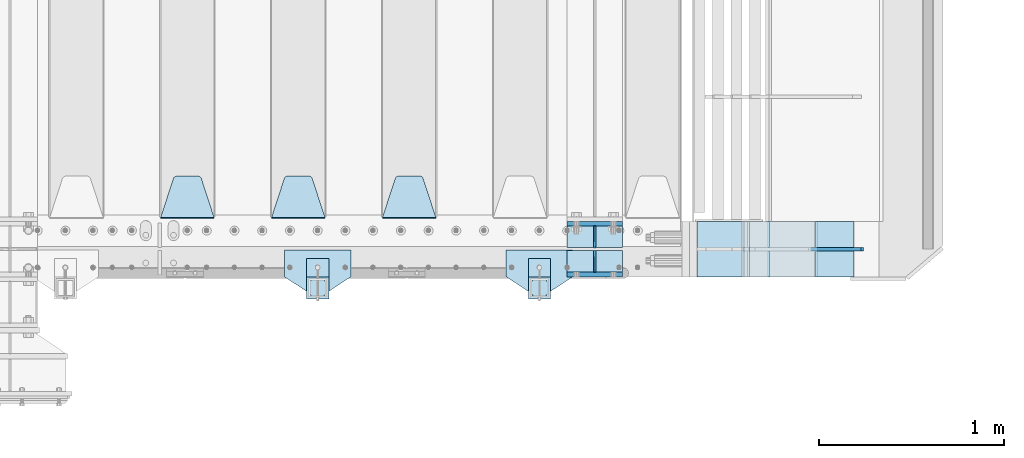
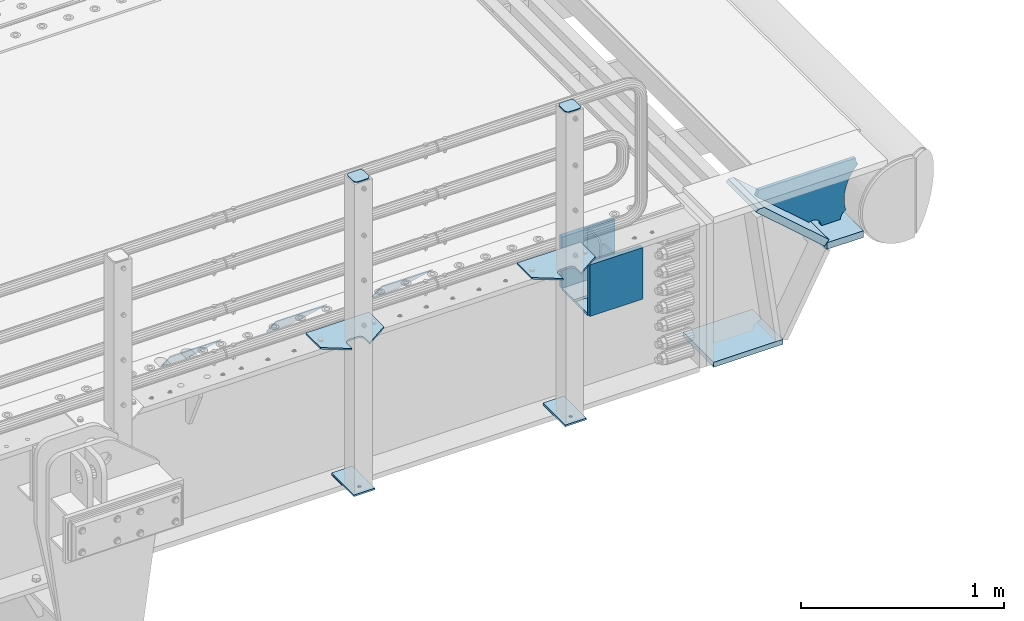
# One storey, part 168 of 193: 21 plates.
"""IFC2X3 building model written with IfcOpenShell, lengths in millimetres."""

from ifc_helpers import new_model, si_unit, frame, origin_with_axes, place, context, subcontext, project, spatial, faceted_brep, material, type_object, element, save


model = new_model("IFC2X3")

# Units and contexts
model_context = context("Model", 3, precision=1e-05, world=origin_with_axes())
body_context = subcontext(model_context, "Body", "Model", "MODEL_VIEW")
ifc_project = project(units=[si_unit("LENGTHUNIT", "METRE", prefix="MILLI"), si_unit("AREAUNIT", "SQUARE_METRE"), si_unit("VOLUMEUNIT", "CUBIC_METRE"), si_unit("MASSUNIT", "GRAM", prefix="KILO"), si_unit("TIMEUNIT", "SECOND"), si_unit("PLANEANGLEUNIT", "RADIAN"), si_unit("SOLIDANGLEUNIT", "STERADIAN"), si_unit("THERMODYNAMICTEMPERATUREUNIT", "DEGREE_CELSIUS"), si_unit("LUMINOUSINTENSITYUNIT", "LUMEN")], contexts=[model_context])

# Site, building, storey
site_placement = place(None, origin_with_axes())
site = spatial("IfcSite", under=ifc_project, at=site_placement, CompositionType="ELEMENT")
building_placement = place(site_placement, origin_with_axes())
building = spatial("IfcBuilding", under=site, at=building_placement, Name="Standard", CompositionType="ELEMENT")
storey_placement = place(building_placement, origin_with_axes())
storey = spatial("IfcBuildingStorey", under=building, at=storey_placement, Name="Undefined", CompositionType="ELEMENT", Elevation=0.0)

# Plates
ifc_material_1 = material(Name="STEEL/S355N")
plate_type_1 = type_object("IfcPlateType", PredefinedType="NOTDEFINED")
for number, where, z_axis, x_axis in (
    (1, (-29045.0, 23862.5, -339.999999999995), (0.0, 0.0, 1.0), (1.0, 0.0, 0.0)),
    (2, (-29045.0, 24137.5, -339.999999999995), (0.0, 0.0, 1.0), (1.0, 0.0, 0.0)),
):
    element("IfcPlate", number, at=place(storey_placement, frame(where, z_axis=z_axis, x_axis=x_axis)), inside=storey, type_object=plate_type_1, material=ifc_material_1, context=body_context, shape_type="Brep", body=[
        faceted_brep([(0.0, -12.5, 0.0), (0.0, -12.5, 310.0), (0.0, 12.5, 310.0), (0.0, 12.5, 0.0), (300.0, -12.5, 310.0), (300.0, 12.5, 310.0), (300.0, -12.5, 0.0), (300.0, 12.5, 0.0)], [[[0, 1, 2, 3]], [[1, 4, 5, 2]], [[4, 6, 7, 5]], [[6, 0, 3, 7]], [[5, 7, 3, 2]], [[6, 4, 1, 0]]]),
    ])
plate_type_2 = type_object("IfcPlateType", PredefinedType="NOTDEFINED")
for number, where, z_axis, x_axis in (
    (3, (-29045.0, 24008.0, -342.999999999995), (0.0, 1.0, 0.0), (1.0, 0.0, 0.0)),
    (4, (-29045.0, 23992.0, -342.999999999995), (0.0, -1.0, 0.0), (1.0, 0.0, 0.0)),
):
    element("IfcPlate", number, at=place(storey_placement, frame(where, z_axis=z_axis, x_axis=x_axis)), inside=storey, type_object=plate_type_2, material=ifc_material_1, context=body_context, shape_type="Brep", body=[
        faceted_brep([(0.0, -7.0, 0.0), (0.0, -7.0, 117.0), (0.0, 7.0, 117.0), (0.0, 7.0, 0.0), (300.0, -7.0, 117.0), (300.0, 7.0, 117.0), (300.0, -7.0, 0.0), (300.0, 7.0, 0.0)], [[[0, 1, 2, 3]], [[1, 4, 5, 2]], [[4, 6, 7, 5]], [[6, 0, 3, 7]], [[5, 7, 3, 2]], [[6, 4, 1, 0]]]),
    ])
plate_type_3 = type_object("IfcPlateType", PredefinedType="NOTDEFINED")
for number, where, z_axis, x_axis in (
    (5, (-28895.0, 23992.0, -29.9999999999945), (0.0, 0.0, -1.0), (0.0, -1.0, 0.0)),
    (6, (-28895.0, 24008.0, -29.9999999999945), (0.0, 0.0, -1.0), (0.0, 1.0, 0.0)),
):
    element("IfcPlate", number, at=place(storey_placement, frame(where, z_axis=z_axis, x_axis=x_axis)), inside=storey, type_object=plate_type_3, material=ifc_material_1, context=body_context, shape_type="Brep", body=[
        faceted_brep([(0.0, -5.0, 30.0), (0.0, -5.0, 306.0), (0.0, 5.0, 306.0), (0.0, 5.0, 30.0), (117.0, -5.0, 306.0), (117.0, 5.0, 306.0), (117.0, -5.0, 0.0), (117.0, 5.0, 0.0), (30.0, -5.0, 0.0), (30.0, 5.0, 0.0), (24.7905546699913, -5.0, 0.455767409633758), (24.7905546699913, 5.0, 0.455767409633758), (19.7393957002314, -5.0, 1.80922137642275), (19.7393957002314, 5.0, 1.80922137642275), (15.0, -5.0, 4.01923788646684), (15.0, 5.0, 4.01923788646684), (10.7163717094045, -5.0, 7.01866670643066), (10.7163717094045, 5.0, 7.01866670643066), (7.01866670642994, -5.0, 10.7163717094038), (7.01866670642994, 5.0, 10.7163717094038), (4.01923788646673, -5.0, 15.0), (4.01923788646673, 5.0, 15.0), (1.80922137642119, -5.0, 19.7393957002299), (1.80922137642119, 5.0, 19.7393957002299), (0.455767409632244, -5.0, 24.7905546699921), (0.455767409632244, 5.0, 24.7905546699921)], [[[0, 1, 2, 3]], [[1, 4, 5, 2]], [[4, 6, 7, 5]], [[6, 8, 9, 7]], [[8, 10, 11, 9]], [[10, 12, 13, 11]], [[12, 14, 15, 13]], [[14, 16, 17, 15]], [[16, 18, 19, 17]], [[18, 20, 21, 19]], [[20, 22, 23, 21]], [[22, 24, 25, 23]], [[24, 0, 3, 25]], [[5, 7, 9, 11, 13, 15, 17, 19, 21, 23, 25, 3, 2]], [[24, 22, 20, 18, 16, 14, 12, 10, 8, 6, 4, 1, 0]]]),
    ])
plate_type_4 = type_object("IfcPlateType", PredefinedType="NOTDEFINED")
plate_1_placement = place(storey_placement, frame((-29755.0, 24168.232233047, -1.76776695296758), z_axis=(0.0, 0.707106781186547, -0.707106781186548), x_axis=(-1.0, 0.0, 0.0)))
element("IfcPlate", 7, at=plate_1_placement, inside=storey, type_object=plate_type_4, material=ifc_material_1, context=body_context, shape_type="Brep", body=[
    faceted_brep([(0.0, -2.5, 0.0), (69.345504679477, -2.50000000000364, 300.171731424831), (69.345504679477, 2.49999999999636, 300.171731424831), (0.0, 2.5, 0.0), (70.9274061199576, -2.50000000000364, 304.897442415397), (70.9274061199576, 2.49999999999636, 304.897442415397), (73.3818627772307, -2.50000000000364, 309.234538108529), (73.3818627772307, 2.49999999999636, 309.234538108529), (76.6187032999551, -2.50000000000728, 313.023683126103), (76.6187032999551, 2.49999999999636, 313.023683126103), (80.5190132704993, -2.50000000000364, 316.125672595372), (80.5190132704993, 2.49999999999636, 316.125672595368), (84.9395038596849, -2.50000000000364, 318.426546230472), (84.9395038596849, 2.49999999999636, 318.426546230476), (89.7177759439219, -2.50000000000364, 319.841774983273), (89.7177759439219, 2.49999999999636, 319.841774983277), (94.678286292652, -2.50000000000364, 320.319366455074), (94.678286292652, 2.49999999999636, 320.319366455074), (195.321713707348, -2.50000000000364, 320.319366455074), (195.321713707348, 2.49999999999636, 320.319366455074), (200.282224056078, -2.50000000000364, 319.841774983273), (200.282224056078, 2.49999999999636, 319.841774983277), (205.060496140315, -2.50000000000364, 318.426546230472), (205.060496140315, 2.49999999999636, 318.426546230472), (209.480986729501, -2.50000000000364, 316.125672595372), (209.480986729501, 2.49999999999636, 316.125672595368), (213.381296700045, -2.50000000000728, 313.023683126103), (213.381296700045, 2.49999999999272, 313.023683126103), (216.618137222769, -2.50000000000364, 309.234538108525), (216.618137222769, 2.49999999999636, 309.234538108522), (219.072593880042, -2.50000000000364, 304.897442415397), (219.072593880042, 2.49999999999636, 304.897442415397), (220.654495320523, -2.50000000000364, 300.171731424831), (220.654495320523, 2.49999999999636, 300.171731424831), (290.0, -2.50000000000364, 0.0), (290.0, 2.49999999999636, 0.0)], [[[0, 1, 2, 3]], [[1, 4, 5, 2]], [[4, 6, 7, 5]], [[6, 8, 9, 7]], [[8, 10, 11, 9]], [[10, 12, 13, 11]], [[12, 14, 15, 13]], [[14, 16, 17, 15]], [[16, 18, 19, 17]], [[18, 20, 21, 19]], [[20, 22, 23, 21]], [[22, 24, 25, 23]], [[24, 26, 27, 25]], [[26, 28, 29, 27]], [[28, 30, 31, 29]], [[30, 32, 33, 31]], [[32, 34, 35, 33]], [[34, 0, 3, 35]], [[5, 7, 9, 11, 13, 15, 17, 19, 21, 23, 25, 27, 29, 31, 33, 35, 3, 2]], [[34, 32, 30, 28, 26, 24, 22, 20, 18, 16, 14, 12, 10, 8, 6, 4, 1, 0]]]),
])
plate_2_placement = place(storey_placement, frame((-30355.0, 24168.232233047, -1.76776695296758), z_axis=(0.0, 0.707106781186547, -0.707106781186548), x_axis=(-1.0, 0.0, 0.0)))
element("IfcPlate", 8, at=plate_2_placement, inside=storey, type_object=plate_type_4, material=ifc_material_1, context=body_context, shape_type="Brep", body=[
    faceted_brep([(0.0, -2.5, 0.0), (69.345504679477, -2.50000000000364, 300.171731424831), (69.345504679477, 2.49999999999636, 300.171731424831), (0.0, 2.5, 0.0), (70.9274061199576, -2.50000000000364, 304.897442415397), (70.9274061199576, 2.49999999999636, 304.897442415397), (73.3818627772307, -2.50000000000364, 309.234538108529), (73.3818627772307, 2.49999999999636, 309.234538108529), (76.6187032999551, -2.50000000000728, 313.023683126103), (76.6187032999551, 2.49999999999636, 313.023683126103), (80.5190132704993, -2.50000000000364, 316.125672595372), (80.5190132704993, 2.49999999999636, 316.125672595368), (84.9395038596849, -2.50000000000364, 318.426546230472), (84.9395038596849, 2.49999999999636, 318.426546230476), (89.7177759439219, -2.50000000000364, 319.841774983273), (89.7177759439219, 2.49999999999636, 319.841774983277), (94.678286292652, -2.50000000000364, 320.319366455074), (94.678286292652, 2.49999999999636, 320.319366455074), (195.321713707348, -2.50000000000364, 320.319366455074), (195.321713707348, 2.49999999999636, 320.319366455074), (200.282224056078, -2.50000000000364, 319.841774983273), (200.282224056078, 2.49999999999636, 319.841774983277), (205.060496140315, -2.50000000000364, 318.426546230472), (205.060496140315, 2.49999999999636, 318.426546230472), (209.480986729501, -2.50000000000364, 316.125672595372), (209.480986729501, 2.49999999999636, 316.125672595368), (213.381296700045, -2.50000000000728, 313.023683126103), (213.381296700045, 2.49999999999272, 313.023683126103), (216.618137222769, -2.50000000000364, 309.234538108525), (216.618137222769, 2.49999999999636, 309.234538108522), (219.072593880042, -2.50000000000364, 304.897442415397), (219.072593880042, 2.49999999999636, 304.897442415397), (220.654495320523, -2.50000000000364, 300.171731424831), (220.654495320523, 2.49999999999636, 300.171731424831), (290.0, -2.50000000000364, 0.0), (290.0, 2.49999999999636, 0.0)], [[[0, 1, 2, 3]], [[1, 4, 5, 2]], [[4, 6, 7, 5]], [[6, 8, 9, 7]], [[8, 10, 11, 9]], [[10, 12, 13, 11]], [[12, 14, 15, 13]], [[14, 16, 17, 15]], [[16, 18, 19, 17]], [[18, 20, 21, 19]], [[20, 22, 23, 21]], [[22, 24, 25, 23]], [[24, 26, 27, 25]], [[26, 28, 29, 27]], [[28, 30, 31, 29]], [[30, 32, 33, 31]], [[32, 34, 35, 33]], [[34, 0, 3, 35]], [[5, 7, 9, 11, 13, 15, 17, 19, 21, 23, 25, 27, 29, 31, 33, 35, 3, 2]], [[34, 32, 30, 28, 26, 24, 22, 20, 18, 16, 14, 12, 10, 8, 6, 4, 1, 0]]]),
])
plate_3_placement = place(storey_placement, frame((-30955.0, 24168.232233047, -1.76776695296758), z_axis=(0.0, 0.707106781186547, -0.707106781186548), x_axis=(-1.0, 0.0, 0.0)))
element("IfcPlate", 9, at=plate_3_placement, inside=storey, type_object=plate_type_4, material=ifc_material_1, context=body_context, shape_type="Brep", body=[
    faceted_brep([(0.0, -2.5, 0.0), (69.345504679477, -2.50000000000364, 300.171731424831), (69.345504679477, 2.49999999999636, 300.171731424831), (0.0, 2.5, 0.0), (70.9274061199576, -2.50000000000364, 304.897442415397), (70.9274061199576, 2.49999999999636, 304.897442415397), (73.3818627772307, -2.50000000000364, 309.234538108529), (73.3818627772307, 2.49999999999636, 309.234538108529), (76.6187032999551, -2.50000000000728, 313.023683126103), (76.6187032999551, 2.49999999999636, 313.023683126103), (80.5190132704993, -2.50000000000364, 316.125672595372), (80.5190132704993, 2.49999999999636, 316.125672595368), (84.9395038596849, -2.50000000000364, 318.426546230472), (84.9395038596849, 2.49999999999636, 318.426546230476), (89.7177759439219, -2.50000000000364, 319.841774983273), (89.7177759439219, 2.49999999999636, 319.841774983277), (94.678286292652, -2.50000000000364, 320.319366455074), (94.678286292652, 2.49999999999636, 320.319366455074), (195.321713707348, -2.50000000000364, 320.319366455074), (195.321713707348, 2.49999999999636, 320.319366455074), (200.282224056078, -2.50000000000364, 319.841774983273), (200.282224056078, 2.49999999999636, 319.841774983277), (205.060496140315, -2.50000000000364, 318.426546230472), (205.060496140315, 2.49999999999636, 318.426546230472), (209.480986729501, -2.50000000000364, 316.125672595372), (209.480986729501, 2.49999999999636, 316.125672595368), (213.381296700045, -2.50000000000728, 313.023683126103), (213.381296700045, 2.49999999999272, 313.023683126103), (216.618137222769, -2.50000000000364, 309.234538108525), (216.618137222769, 2.49999999999636, 309.234538108522), (219.072593880042, -2.50000000000364, 304.897442415397), (219.072593880042, 2.49999999999636, 304.897442415397), (220.654495320523, -2.50000000000364, 300.171731424831), (220.654495320523, 2.49999999999636, 300.171731424831), (290.0, -2.50000000000364, 0.0), (290.0, 2.49999999999636, 0.0)], [[[0, 1, 2, 3]], [[1, 4, 5, 2]], [[4, 6, 7, 5]], [[6, 8, 9, 7]], [[8, 10, 11, 9]], [[10, 12, 13, 11]], [[12, 14, 15, 13]], [[14, 16, 17, 15]], [[16, 18, 19, 17]], [[18, 20, 21, 19]], [[20, 22, 23, 21]], [[22, 24, 25, 23]], [[24, 26, 27, 25]], [[26, 28, 29, 27]], [[28, 30, 31, 29]], [[30, 32, 33, 31]], [[32, 34, 35, 33]], [[34, 0, 3, 35]], [[5, 7, 9, 11, 13, 15, 17, 19, 21, 23, 25, 27, 29, 31, 33, 35, 3, 2]], [[34, 32, 30, 28, 26, 24, 22, 20, 18, 16, 14, 12, 10, 8, 6, 4, 1, 0]]]),
])
ifc_material_2 = material(Name="STEEL/S355J2")
plate_type_5 = type_object("IfcPlateType", PredefinedType="NOTDEFINED")
plate_4_placement = place(storey_placement, frame((-29015.0, 23995.0, 5.00000000004911), z_axis=(0.0, -1.0, 0.0), x_axis=(-1.0, 0.0, 0.0)))
element("IfcPlate", 10, at=plate_4_placement, inside=storey, type_object=plate_type_5, material=ifc_material_2, context=body_context, shape_type="Brep", body=[
    faceted_brep([(0.0, -5.0, 0.0), (2.31396552408114e-06, -5.0, 145.0), (2.31396552408114e-06, 5.0, 145.0), (0.0, 5.0, 0.0), (130.0, -5.0, 230.0), (130.0, 5.0, 230.0), (130.0, -5.0, 180.0), (130.0, 5.0, 180.0), (130.48036798992, -5.0, 175.122741949595), (130.48036798992, 5.0, 175.122741949595), (131.903011687216, -5.0, 170.432914190871), (131.903011687216, 5.0, 170.432914190871), (134.213259692435, -5.0, 166.110744174512), (134.213259692435, 5.0, 166.110744174512), (137.322330470335, -5.0, 162.322330470335), (137.322330470335, 5.0, 162.322330470335), (141.110744174512, -5.0, 159.213259692435), (141.110744174512, 5.0, 159.213259692435), (145.432914190871, -5.0, 156.903011687216), (145.432914190871, 5.0, 156.903011687216), (150.122741949595, -5.0, 155.48036798992), (150.122741949595, 5.0, 155.48036798992), (155.0, -5.0, 155.0), (155.0, 5.0, 155.0), (205.0, -5.0, 155.0), (205.0, 5.0, 155.0), (209.877258050405, -5.0, 155.48036798992), (209.877258050405, 5.0, 155.48036798992), (214.567085809129, -5.0, 156.903011687216), (214.567085809129, 5.0, 156.903011687216), (218.889255825488, -5.0, 159.213259692435), (218.889255825488, 5.0, 159.213259692435), (222.677669529665, -5.0, 162.322330470335), (222.677669529665, 5.0, 162.322330470335), (225.786740307565, -5.0, 166.110744174512), (225.786740307565, 5.0, 166.110744174512), (228.096988312784, -5.0, 170.432914190871), (228.096988312784, 5.0, 170.432914190871), (229.51963201008, -5.0, 175.122741949595), (229.51963201008, 5.0, 175.122741949595), (230.0, -5.0, 180.0), (230.0, 5.0, 180.0), (230.0, -5.0, 230.0), (230.0, 5.0, 230.0), (360.0, -5.0, 145.0), (360.0, 5.0, 145.0), (360.0, -5.0, -7.27595761418343e-12), (360.0, 5.0, -7.27595761418343e-12)], [[[0, 1, 2, 3]], [[1, 4, 5, 2]], [[4, 6, 7, 5]], [[6, 8, 9, 7]], [[8, 10, 11, 9]], [[10, 12, 13, 11]], [[12, 14, 15, 13]], [[14, 16, 17, 15]], [[16, 18, 19, 17]], [[18, 20, 21, 19]], [[20, 22, 23, 21]], [[22, 24, 25, 23]], [[24, 26, 27, 25]], [[26, 28, 29, 27]], [[28, 30, 31, 29]], [[30, 32, 33, 31]], [[32, 34, 35, 33]], [[34, 36, 37, 35]], [[36, 38, 39, 37]], [[38, 40, 41, 39]], [[40, 42, 43, 41]], [[42, 44, 45, 43]], [[44, 46, 47, 45]], [[46, 0, 3, 47]], [[5, 7, 9, 11, 13, 15, 17, 19, 21, 23, 25, 27, 29, 31, 33, 35, 37, 39, 41, 43, 45, 47, 3, 2]], [[46, 44, 42, 40, 38, 36, 34, 32, 30, 28, 26, 24, 22, 20, 18, 16, 14, 12, 10, 8, 6, 4, 1, 0]]]),
])
plate_5_placement = place(storey_placement, frame((-30215.0, 23995.0, 5.00000000004911), z_axis=(0.0, -1.0, 0.0), x_axis=(-1.0, 0.0, 0.0)))
element("IfcPlate", 11, at=plate_5_placement, inside=storey, type_object=plate_type_5, material=ifc_material_2, context=body_context, shape_type="Brep", body=[
    faceted_brep([(0.0, -5.0, 0.0), (2.31396552408114e-06, -5.0, 145.0), (2.31396552408114e-06, 5.0, 145.0), (0.0, 5.0, 0.0), (130.0, -5.0, 230.0), (130.0, 5.0, 230.0), (130.0, -5.0, 180.0), (130.0, 5.0, 180.0), (130.48036798992, -5.0, 175.122741949595), (130.48036798992, 5.0, 175.122741949595), (131.903011687216, -5.0, 170.432914190871), (131.903011687216, 5.0, 170.432914190871), (134.213259692435, -5.0, 166.110744174512), (134.213259692435, 5.0, 166.110744174512), (137.322330470335, -5.0, 162.322330470335), (137.322330470335, 5.0, 162.322330470335), (141.110744174512, -5.0, 159.213259692435), (141.110744174512, 5.0, 159.213259692435), (145.432914190871, -5.0, 156.903011687216), (145.432914190871, 5.0, 156.903011687216), (150.122741949595, -5.0, 155.48036798992), (150.122741949595, 5.0, 155.48036798992), (155.0, -5.0, 155.0), (155.0, 5.0, 155.0), (205.0, -5.0, 155.0), (205.0, 5.0, 155.0), (209.877258050405, -5.0, 155.48036798992), (209.877258050405, 5.0, 155.48036798992), (214.567085809129, -5.0, 156.903011687216), (214.567085809129, 5.0, 156.903011687216), (218.889255825488, -5.0, 159.213259692435), (218.889255825488, 5.0, 159.213259692435), (222.677669529665, -5.0, 162.322330470335), (222.677669529665, 5.0, 162.322330470335), (225.786740307565, -5.0, 166.110744174512), (225.786740307565, 5.0, 166.110744174512), (228.096988312784, -5.0, 170.432914190871), (228.096988312784, 5.0, 170.432914190871), (229.51963201008, -5.0, 175.122741949595), (229.51963201008, 5.0, 175.122741949595), (230.0, -5.0, 180.0), (230.0, 5.0, 180.0), (230.0, -5.0, 230.0), (230.0, 5.0, 230.0), (360.0, -5.0, 145.0), (360.0, 5.0, 145.0), (360.0, -5.0, -7.27595761418343e-12), (360.0, 5.0, -7.27595761418343e-12)], [[[0, 1, 2, 3]], [[1, 4, 5, 2]], [[4, 6, 7, 5]], [[6, 8, 9, 7]], [[8, 10, 11, 9]], [[10, 12, 13, 11]], [[12, 14, 15, 13]], [[14, 16, 17, 15]], [[16, 18, 19, 17]], [[18, 20, 21, 19]], [[20, 22, 23, 21]], [[22, 24, 25, 23]], [[24, 26, 27, 25]], [[26, 28, 29, 27]], [[28, 30, 31, 29]], [[30, 32, 33, 31]], [[32, 34, 35, 33]], [[34, 36, 37, 35]], [[36, 38, 39, 37]], [[38, 40, 41, 39]], [[40, 42, 43, 41]], [[42, 44, 45, 43]], [[44, 46, 47, 45]], [[46, 0, 3, 47]], [[5, 7, 9, 11, 13, 15, 17, 19, 21, 23, 25, 27, 29, 31, 33, 35, 37, 39, 41, 43, 45, 47, 3, 2]], [[46, 44, 42, 40, 38, 36, 34, 32, 30, 28, 26, 24, 22, 20, 18, 16, 14, 12, 10, 8, 6, 4, 1, 0]]]),
])
plate_type_6 = type_object("IfcPlateType", PredefinedType="NOTDEFINED")
for number, where, z_axis, x_axis in (
    (12, (-29135.0000000001, 23949.9999999998, -850.000000000002), (0.0, -1.0, 0.0), (-1.0, 0.0, 0.0)),
    (13, (-30335.0000000001, 23949.9999999998, -850.000000000002), (0.0, -1.0, 0.0), (-1.0, 0.0, 0.0)),
):
    element("IfcPlate", number, at=place(storey_placement, frame(where, z_axis=z_axis, x_axis=x_axis)), inside=storey, type_object=plate_type_6, material=ifc_material_2, context=body_context, shape_type="Brep", body=[
        faceted_brep([(53.6360389691836, -5.0, 176.363961030467), (53.6360389691836, 5.0, 176.363961030467), (59.9999999998618, 5.0, 178.999999999789), (59.9999999998618, -5.0, 178.999999999789), (66.3639610305399, 5.0, 176.363961030467), (66.3639610305399, -5.0, 176.363961030467), (68.9999999998618, 5.0, 169.999999999789), (68.9999999998618, -5.0, 169.999999999789), (66.3639610305399, 5.0, 163.636038969111), (66.3639610305399, -5.0, 163.636038969111), (59.9999999998618, 5.0, 160.999999999789), (59.9999999998618, -5.0, 160.999999999789), (53.6360389691836, 5.0, 163.636038969111), (53.6360389691836, -5.0, 163.636038969111), (50.9999999998618, 5.0, 169.999999999789), (50.9999999998618, -5.0, 169.999999999789), (120.0, -5.0, 0.0), (120.0, -5.0, 220.0), (0.0, -5.0, 220.0), (0.0, -5.0, 0.0), (0.0, 5.0, 0.0), (120.0, 5.0, 0.0), (120.0, 5.0, 220.0), (0.0, 5.0, 220.0)], [[[0, 1, 2, 3]], [[3, 2, 4, 5]], [[5, 4, 6, 7]], [[7, 6, 8, 9]], [[9, 8, 10, 11]], [[11, 10, 12, 13]], [[13, 12, 14, 15]], [[15, 14, 1, 0]], [[16, 17, 18, 19], [11, 13, 15, 0, 3, 5, 7, 9]], [[16, 19, 20, 21]], [[17, 16, 21, 22]], [[18, 17, 22, 23]], [[19, 18, 23, 20]], [[22, 21, 20, 23], [2, 1, 14, 12, 10, 8, 6, 4]]]),
    ])
plate_type_7 = type_object("IfcPlateType", PredefinedType="NOTDEFINED")
plate_6_placement = place(storey_placement, frame((-29239.0000000001, 23833.9999999998, 1012.50000000001), z_axis=(0.0, -1.0, 0.0), x_axis=(1.0, 0.0, 0.0)))
element("IfcPlate", 14, at=plate_6_placement, inside=storey, type_object=plate_type_7, material=ifc_material_2, context=body_context, shape_type="Brep", body=[
    faceted_brep([(0.0, -2.5, 19.0), (0.0, -2.5, 69.0), (0.0, 2.5, 69.0), (0.0, 2.5, 19.0), (0.476369668544066, -2.5, 73.2278977451715), (0.476369668544066, 2.5, 73.2278977451715), (1.88159150985302, -2.5, 77.2437910432345), (1.88159150985302, 2.5, 77.2437910432345), (4.14520183310742, -2.5, 80.8463062353148), (4.14520183310742, 2.5, 80.8463062353148), (7.15369376468516, -2.5, 83.8547981668926), (7.15369376468516, 2.5, 83.8547981668926), (10.7562089567655, -2.5, 86.118408490147), (10.7562089567655, 2.5, 86.118408490147), (14.7721022548285, -2.5, 87.5236303314559), (14.7721022548285, 2.5, 87.5236303314559), (19.0, -2.5, 88.0), (19.0, 2.5, 88.0), (69.0, -2.5, 88.0), (69.0, 2.5, 88.0), (73.2278977451715, -2.5, 87.5236303314559), (73.2278977451715, 2.5, 87.5236303314559), (77.2437910432345, -2.5, 86.118408490147), (77.2437910432345, 2.5, 86.118408490147), (80.8463062353148, -2.5, 83.8547981668926), (80.8463062353148, 2.5, 83.8547981668926), (83.8547981668926, -2.5, 80.8463062353148), (83.8547981668926, 2.5, 80.8463062353148), (86.118408490147, -2.5, 77.2437910432345), (86.118408490147, 2.5, 77.2437910432345), (87.5236303314559, -2.5, 73.2278977451715), (87.5236303314559, 2.5, 73.2278977451715), (88.0, -2.5, 69.0), (88.0, 2.5, 69.0), (88.0, -2.5, 19.0), (88.0, 2.5, 19.0), (87.5236303314559, -2.5, 14.7721022548285), (87.5236303314559, 2.5, 14.7721022548285), (86.118408490147, -2.5, 10.7562089567655), (86.118408490147, 2.5, 10.7562089567655), (83.8547981668926, -2.5, 7.15369376468516), (83.8547981668926, 2.5, 7.15369376468516), (80.8463062353148, -2.5, 4.14520183310742), (80.8463062353148, 2.5, 4.14520183310742), (77.2437910432345, -2.5, 1.88159150985302), (77.2437910432345, 2.5, 1.88159150985302), (73.2278977451715, -2.5, 0.476369668544066), (73.2278977451715, 2.5, 0.476369668544066), (69.0, -2.5, 0.0), (69.0, 2.5, 0.0), (19.0, -2.5, 0.0), (19.0, 2.5, 0.0), (14.7721022548285, -2.5, 0.476369668544066), (14.7721022548285, 2.5, 0.476369668544066), (10.7562089567655, -2.5, 1.88159150985302), (10.7562089567655, 2.5, 1.88159150985302), (7.15369376468516, -2.5, 4.14520183310742), (7.15369376468516, 2.5, 4.14520183310742), (4.14520183310742, -2.5, 7.15369376468516), (4.14520183310742, 2.5, 7.15369376468516), (1.88159150985302, -2.5, 10.7562089567655), (1.88159150985302, 2.5, 10.7562089567655), (0.476369668544066, -2.5, 14.7721022548285), (0.476369668544066, 2.5, 14.7721022548285)], [[[0, 1, 2, 3]], [[1, 4, 5, 2]], [[4, 6, 7, 5]], [[6, 8, 9, 7]], [[8, 10, 11, 9]], [[10, 12, 13, 11]], [[12, 14, 15, 13]], [[14, 16, 17, 15]], [[16, 18, 19, 17]], [[18, 20, 21, 19]], [[20, 22, 23, 21]], [[22, 24, 25, 23]], [[24, 26, 27, 25]], [[26, 28, 29, 27]], [[28, 30, 31, 29]], [[30, 32, 33, 31]], [[32, 34, 35, 33]], [[34, 36, 37, 35]], [[36, 38, 39, 37]], [[38, 40, 41, 39]], [[40, 42, 43, 41]], [[42, 44, 45, 43]], [[44, 46, 47, 45]], [[46, 48, 49, 47]], [[48, 50, 51, 49]], [[50, 52, 53, 51]], [[52, 54, 55, 53]], [[54, 56, 57, 55]], [[56, 58, 59, 57]], [[58, 60, 61, 59]], [[60, 62, 63, 61]], [[62, 0, 3, 63]], [[5, 7, 9, 11, 13, 15, 17, 19, 21, 23, 25, 27, 29, 31, 33, 35, 37, 39, 41, 43, 45, 47, 49, 51, 53, 55, 57, 59, 61, 63, 3, 2]], [[62, 60, 58, 56, 54, 52, 50, 48, 46, 44, 42, 40, 38, 36, 34, 32, 30, 28, 26, 24, 22, 20, 18, 16, 14, 12, 10, 8, 6, 4, 1, 0]]]),
])
plate_7_placement = place(storey_placement, frame((-30439.0000000001, 23833.9999999998, 1012.50000000001), z_axis=(0.0, -1.0, 0.0), x_axis=(1.0, 0.0, 0.0)))
element("IfcPlate", 15, at=plate_7_placement, inside=storey, type_object=plate_type_7, material=ifc_material_2, context=body_context, shape_type="Brep", body=[
    faceted_brep([(0.0, -2.5, 19.0), (0.0, -2.5, 69.0), (0.0, 2.5, 69.0), (0.0, 2.5, 19.0), (0.476369668544066, -2.5, 73.2278977451715), (0.476369668544066, 2.5, 73.2278977451715), (1.88159150985302, -2.5, 77.2437910432345), (1.88159150985302, 2.5, 77.2437910432345), (4.14520183310742, -2.5, 80.8463062353148), (4.14520183310742, 2.5, 80.8463062353148), (7.15369376468516, -2.5, 83.8547981668926), (7.15369376468516, 2.5, 83.8547981668926), (10.7562089567655, -2.5, 86.118408490147), (10.7562089567655, 2.5, 86.118408490147), (14.7721022548285, -2.5, 87.5236303314559), (14.7721022548285, 2.5, 87.5236303314559), (19.0, -2.5, 88.0), (19.0, 2.5, 88.0), (69.0, -2.5, 88.0), (69.0, 2.5, 88.0), (73.2278977451715, -2.5, 87.5236303314559), (73.2278977451715, 2.5, 87.5236303314559), (77.2437910432345, -2.5, 86.118408490147), (77.2437910432345, 2.5, 86.118408490147), (80.8463062353148, -2.5, 83.8547981668926), (80.8463062353148, 2.5, 83.8547981668926), (83.8547981668926, -2.5, 80.8463062353148), (83.8547981668926, 2.5, 80.8463062353148), (86.118408490147, -2.5, 77.2437910432345), (86.118408490147, 2.5, 77.2437910432345), (87.5236303314559, -2.5, 73.2278977451715), (87.5236303314559, 2.5, 73.2278977451715), (88.0, -2.5, 69.0), (88.0, 2.5, 69.0), (88.0, -2.5, 19.0), (88.0, 2.5, 19.0), (87.5236303314559, -2.5, 14.7721022548285), (87.5236303314559, 2.5, 14.7721022548285), (86.118408490147, -2.5, 10.7562089567655), (86.118408490147, 2.5, 10.7562089567655), (83.8547981668926, -2.5, 7.15369376468516), (83.8547981668926, 2.5, 7.15369376468516), (80.8463062353148, -2.5, 4.14520183310742), (80.8463062353148, 2.5, 4.14520183310742), (77.2437910432345, -2.5, 1.88159150985302), (77.2437910432345, 2.5, 1.88159150985302), (73.2278977451715, -2.5, 0.476369668544066), (73.2278977451715, 2.5, 0.476369668544066), (69.0, -2.5, 0.0), (69.0, 2.5, 0.0), (19.0, -2.5, 0.0), (19.0, 2.5, 0.0), (14.7721022548285, -2.5, 0.476369668544066), (14.7721022548285, 2.5, 0.476369668544066), (10.7562089567655, -2.5, 1.88159150985302), (10.7562089567655, 2.5, 1.88159150985302), (7.15369376468516, -2.5, 4.14520183310742), (7.15369376468516, 2.5, 4.14520183310742), (4.14520183310742, -2.5, 7.15369376468516), (4.14520183310742, 2.5, 7.15369376468516), (1.88159150985302, -2.5, 10.7562089567655), (1.88159150985302, 2.5, 10.7562089567655), (0.476369668544066, -2.5, 14.7721022548285), (0.476369668544066, 2.5, 14.7721022548285)], [[[0, 1, 2, 3]], [[1, 4, 5, 2]], [[4, 6, 7, 5]], [[6, 8, 9, 7]], [[8, 10, 11, 9]], [[10, 12, 13, 11]], [[12, 14, 15, 13]], [[14, 16, 17, 15]], [[16, 18, 19, 17]], [[18, 20, 21, 19]], [[20, 22, 23, 21]], [[22, 24, 25, 23]], [[24, 26, 27, 25]], [[26, 28, 29, 27]], [[28, 30, 31, 29]], [[30, 32, 33, 31]], [[32, 34, 35, 33]], [[34, 36, 37, 35]], [[36, 38, 39, 37]], [[38, 40, 41, 39]], [[40, 42, 43, 41]], [[42, 44, 45, 43]], [[44, 46, 47, 45]], [[46, 48, 49, 47]], [[48, 50, 51, 49]], [[50, 52, 53, 51]], [[52, 54, 55, 53]], [[54, 56, 57, 55]], [[56, 58, 59, 57]], [[58, 60, 61, 59]], [[60, 62, 63, 61]], [[62, 0, 3, 63]], [[5, 7, 9, 11, 13, 15, 17, 19, 21, 23, 25, 27, 29, 31, 33, 35, 37, 39, 41, 43, 45, 47, 49, 51, 53, 55, 57, 59, 61, 63, 3, 2]], [[62, 60, 58, 56, 54, 52, 50, 48, 46, 44, 42, 40, 38, 36, 34, 32, 30, 28, 26, 24, 22, 20, 18, 16, 14, 12, 10, 8, 6, 4, 1, 0]]]),
])
plate_type_8 = type_object("IfcPlateType", PredefinedType="NOTDEFINED")
for number, where, z_axis, x_axis in (
    (16, (-29135.0000000001, 23949.9999999998, -857.500000000002), (0.0, -1.0, 0.0), (-1.0, 0.0, 0.0)),
    (17, (-30335.0000000001, 23949.9999999998, -857.500000000002), (0.0, -1.0, 0.0), (-1.0, 0.0, 0.0)),
):
    element("IfcPlate", number, at=place(storey_placement, frame(where, z_axis=z_axis, x_axis=x_axis)), inside=storey, type_object=plate_type_8, material=ifc_material_2, context=body_context, shape_type="Brep", body=[
        faceted_brep([(0.0, -2.5, 0.0), (0.0, -2.5, 100.0), (0.0, 2.5, 100.0), (0.0, 2.5, 0.0), (120.0, -2.5, 100.0), (120.0, 2.5, 100.0), (120.0, -2.5, 0.0), (120.0, 2.5, 0.0)], [[[0, 1, 2, 3]], [[1, 4, 5, 2]], [[4, 6, 7, 5]], [[6, 0, 3, 7]], [[5, 7, 3, 2]], [[6, 4, 1, 0]]]),
    ])
plate_type_9 = type_object("IfcPlateType", PredefinedType="NOTDEFINED")
plate_8_placement = place(storey_placement, frame((-27701.0011701102, 24149.9999999992, -367.999999998984), z_axis=(-0.752989422949573, 0.0, 0.658032619955933), x_axis=(0.0, -1.0, 0.0)))
element("IfcPlate", 18, at=plate_8_placement, inside=storey, type_object=plate_type_9, material=ifc_material_1, context=body_context, shape_type="Brep", body=[
    faceted_brep([(-8.11269273981452e-10, 20.0, 490.766265601622), (0.0, -0.30381125094209, 514.0), (300.0, -0.30381125094209, 514.0), (300.0, 20.0, 490.766265601622), (300.0, -20.0, 0.0), (300.0, -20.0, 514.000000000004), (0.0, -20.0, 514.000000000004), (0.0, -20.0, 0.0), (0.0, 20.0, 0.0), (300.0, 20.0, 0.0)], [[[0, 1, 2, 3]], [[4, 5, 6, 7]], [[4, 7, 8, 9]], [[9, 8, 0, 3]], [[5, 4, 9, 3, 2]], [[6, 5, 2, 1]], [[8, 7, 6, 1, 0]]]),
])
plate_type_10 = type_object("IfcPlateType", PredefinedType="NOTDEFINED")
plate_9_placement = place(storey_placement, frame((-27701.0011701102, 23849.9999999992, -387.999999998984), z_axis=(1.0, 0.0, 0.0), x_axis=(0.0, 1.0, 0.0)))
element("IfcPlate", 19, at=plate_9_placement, inside=storey, type_object=plate_type_10, material=ifc_material_1, context=body_context, shape_type="Brep", body=[
    faceted_brep([(0.0, -20.0, 0.0), (3.31056071445346e-10, -20.0, 208.0), (3.31056071445346e-10, 20.0, 208.0), (0.0, 20.0, 0.0), (300.0, -20.0, 208.0), (300.0, 20.0, 208.0), (300.0, -20.0, 0.0), (300.0, 20.0, 0.0)], [[[0, 1, 2, 3]], [[1, 4, 5, 2]], [[4, 6, 7, 5]], [[6, 0, 3, 7]], [[5, 7, 3, 2]], [[6, 4, 1, 0]]]),
])
plate_type_11 = type_object("IfcPlateType", PredefinedType="NOTDEFINED")
plate_10_placement = place(storey_placement, frame((-27950.0011701109, 24150.0, -875.000000002935), z_axis=(0.0, -1.0, 0.0), x_axis=(-1.0, 0.0, 0.0)))
element("IfcPlate", 20, at=plate_10_placement, inside=storey, type_object=plate_type_11, material=ifc_material_1, context=body_context, shape_type="Brep", body=[
    faceted_brep([(0.0, -15.0, 0.0), (0.0, -15.0, 300.0), (0.0, 15.0, 300.0), (0.0, 15.0, 0.0), (393.0, -15.0, 300.0), (393.0, 15.0, 300.0), (393.0, -15.0, 0.0), (393.0, 15.0, 0.0)], [[[0, 1, 2, 3]], [[1, 4, 5, 2]], [[4, 6, 7, 5]], [[6, 0, 3, 7]], [[5, 7, 3, 2]], [[6, 4, 1, 0]]]),
])
plate_type_12 = type_object("IfcPlateType", PredefinedType="NOTDEFINED")
plate_11_placement = place(storey_placement, frame((-27386.0011701102, 23999.9999999994, -29.9999999989843), z_axis=(-0.000446694000102124, 0.0, -0.99999990023223), x_axis=(-0.99999990023223, 0.0, 0.000446694000103734)))
element("IfcPlate", 21, at=plate_11_placement, inside=storey, type_object=plate_type_12, material=ifc_material_1, context=body_context, shape_type="Brep", body=[
    faceted_brep([(125.007775472983, 10.0, 291.842314882031), (131.755016800053, 10.0, 263.793234614468), (131.755016800053, -10.0, 263.793234614468), (125.007775472983, -10.0, 291.842314882031), (134.899927074483, 10.0, 224.060281342732), (134.899927074483, -10.0, 224.060281342732), (131.79051499522, 10.0, 184.324534302446), (131.79051499522, -10.0, 184.324534302446), (122.503344607208, 10.0, 145.564419461128), (122.503344607208, -10.0, 145.564419461128), (107.267096867745, 10.0, 108.734339483615), (107.267096867745, -10.0, 108.734339483615), (86.4569387623887, 10.0, 74.7411731709829), (86.4569387623887, -10.0, 74.7411731709829), (60.5852854486511, 10.0, 44.4219450946983), (60.5852854486511, -10.0, 44.4219450946983), (56.2519855253086, 10.0, 40.7176084148888), (56.2519855253086, -10.0, 40.7176084148888), (136.409234539125, -10.0, 297.721677540594), (147.386991180581, -10.0, 308.778803581017), (147.386991180581, 10.0, 308.778803581017), (136.409234539125, 10.0, 297.721677540594), (154.428166132755, -10.0, 322.678193223937), (154.428166132755, 10.0, 322.678193223937), (156.849001662977, -10.0, 338.070097995228), (156.849001662977, 10.0, 338.070097995228), (264.849004013293, -10.0, 338.118348049693), (264.849004013293, 10.0, 338.118348049693), (267.62876711955, -10.0, 321.701412969031), (267.62876711955, 10.0, 321.701412969031), (275.645118712178, -10.0, 307.107546191754), (275.645118712178, 10.0, 307.107546191754), (288.009068357209, -10.0, 295.955165748785), (288.009068357209, 10.0, 295.955165748785), (303.34948944753, -10.0, 289.481038692482), (303.34948944753, 10.0, 289.481038692482), (319.965173216926, -10.0, 288.403127172445), (319.965173216926, 10.0, 288.403127172445), (336.013487920231, -10.0, 292.840968489265), (336.013487920231, 10.0, 292.840968489265), (335.869079589844, -10.0, 293.150054931641), (335.869079589844, 10.0, 293.150054931641), (633.937057436444, -10.0, 32.8861672876965), (633.937057436444, 10.0, 32.8861672876965), (628.672097726401, -10.0, 25.6357574923157), (628.672097726401, 10.0, 25.6357574923157), (624.785781531271, -10.0, 17.5620477266102), (624.785781531271, 10.0, 17.5620477266102), (622.402919050601, -10.0, 8.92432757904926), (622.402919050601, 10.0, 8.92432757904926), (621.600036621097, -10.0, -8.74671002293326e-10), (621.600036621097, 10.0, -8.74671002293326e-10), (70.0, -10.0, -9.84954340310651e-11), (70.0, 10.0, -9.84954340310651e-11), (67.7728137216618, -10.0, 17.5170123094482), (67.7728137216618, 10.0, 17.5170123094482), (61.2329794213983, -10.0, 33.9193489203215), (61.2329794213983, 10.0, 33.9193489203215)], [[[0, 1, 2, 3]], [[4, 5, 2, 1]], [[6, 7, 5, 4]], [[8, 9, 7, 6]], [[10, 11, 9, 8]], [[12, 13, 11, 10]], [[14, 15, 13, 12]], [[16, 17, 15, 14]], [[18, 19, 20, 21]], [[19, 22, 23, 20]], [[22, 24, 25, 23]], [[24, 26, 27, 25]], [[26, 28, 29, 27]], [[28, 30, 31, 29]], [[30, 32, 33, 31]], [[32, 34, 35, 33]], [[34, 36, 37, 35]], [[36, 38, 39, 37]], [[38, 40, 41, 39]], [[40, 42, 43, 41]], [[42, 44, 45, 43]], [[44, 46, 47, 45]], [[46, 48, 49, 47]], [[48, 50, 51, 49]], [[50, 52, 53, 51]], [[52, 54, 55, 53]], [[54, 56, 57, 55]], [[12, 10, 8, 6, 4, 1, 0, 21, 20, 23, 25, 27, 29, 31, 33, 35, 37, 39, 41, 43, 45, 47, 49, 51, 53, 55, 57, 16, 14]], [[18, 21, 0, 3]], [[56, 54, 52, 50, 48, 46, 44, 42, 40, 38, 36, 34, 32, 30, 28, 26, 24, 22, 19, 18, 3, 2, 5, 7, 9, 11, 13, 15, 17]], [[57, 56, 17, 16]]]),
])

save(model, "model.ifc")
